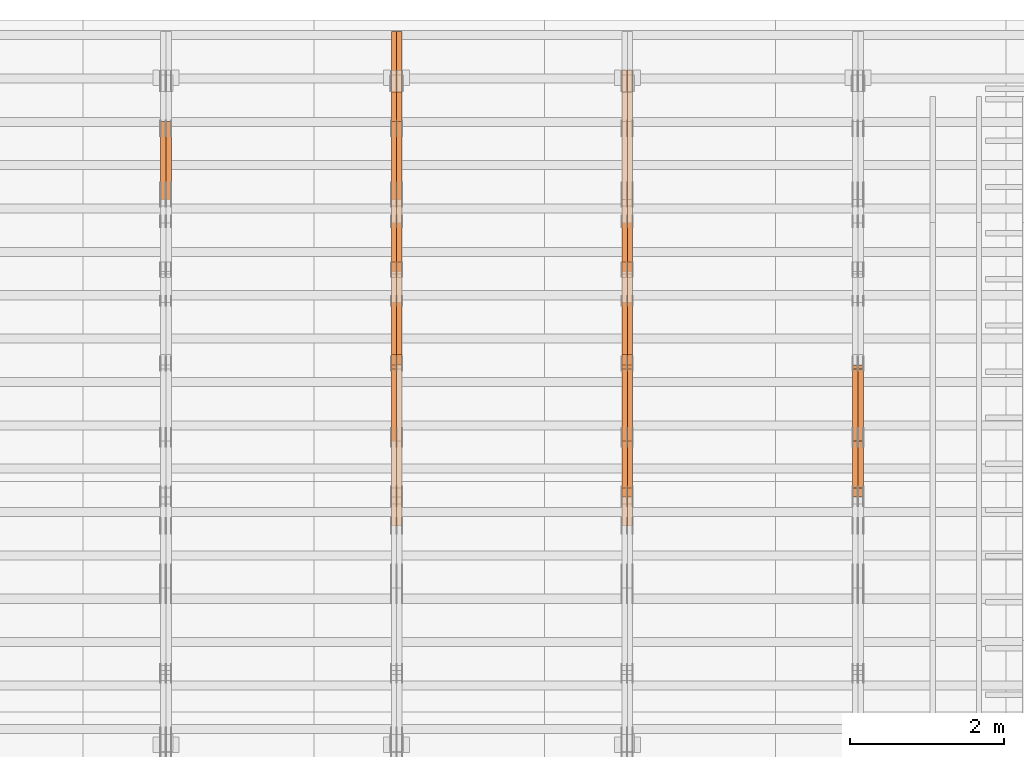
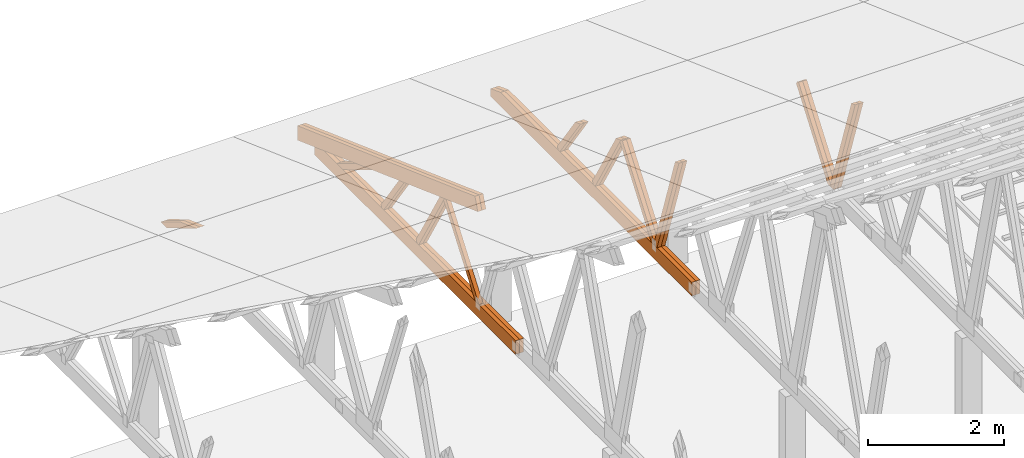
# One storey, part 62 of 189: 27 proxies.
"""IFC2X3 building model written with IfcOpenShell, lengths in millimetres."""

from ifc_helpers import new_model, entity, si_unit, converted_unit, derived_unit, direction, frame, origin, place, context, subcontext, project, spatial, polyline, outline, extrude, source, transform, mapped, material, type_object, type_shapes, element, save


model = new_model("IFC2X3")

# Units and contexts
model_context = context("Model", 3, precision=0.01, world=origin(), true_north=direction((6.12303176911189e-17, 1.0)))
body_context = subcontext(model_context, "Body", "Model", "MODEL_VIEW")
ifc_project = project(units=[si_unit("LENGTHUNIT", "METRE", prefix="MILLI"), si_unit("AREAUNIT", "SQUARE_METRE"), si_unit("VOLUMEUNIT", "CUBIC_METRE"), converted_unit("PLANEANGLEUNIT", "DEGREE", entity("IfcRatioMeasure", 0.0174532925199433), si_unit("PLANEANGLEUNIT", "RADIAN"), dimensions=[0, 0, 0, 0, 0, 0, 0]), si_unit("MASSUNIT", "GRAM", prefix="KILO"), derived_unit("MASSDENSITYUNIT", [(si_unit("MASSUNIT", "GRAM", prefix="KILO"), 1), (si_unit("LENGTHUNIT", "METRE"), -3)]), si_unit("TIMEUNIT", "SECOND"), si_unit("FREQUENCYUNIT", "HERTZ"), si_unit("THERMODYNAMICTEMPERATUREUNIT", "DEGREE_CELSIUS"), derived_unit("THERMALTRANSMITTANCEUNIT", [(si_unit("MASSUNIT", "GRAM", prefix="KILO"), 1), (si_unit("THERMODYNAMICTEMPERATUREUNIT", "KELVIN"), -1), (si_unit("TIMEUNIT", "SECOND"), -3)]), derived_unit("VOLUMETRICFLOWRATEUNIT", [(si_unit("LENGTHUNIT", "METRE"), 3), (si_unit("TIMEUNIT", "SECOND"), -1)]), si_unit("ELECTRICCURRENTUNIT", "AMPERE"), si_unit("ELECTRICVOLTAGEUNIT", "VOLT"), si_unit("POWERUNIT", "WATT"), si_unit("FORCEUNIT", "NEWTON"), si_unit("ILLUMINANCEUNIT", "LUX"), si_unit("LUMINOUSFLUXUNIT", "LUMEN"), si_unit("LUMINOUSINTENSITYUNIT", "CANDELA"), derived_unit("USERDEFINED", [(si_unit("MASSUNIT", "GRAM", prefix="KILO"), -1), (si_unit("LENGTHUNIT", "METRE"), -2), (si_unit("TIMEUNIT", "SECOND"), 3), (si_unit("LUMINOUSFLUXUNIT", "LUMEN"), 1)]), derived_unit("LINEARVELOCITYUNIT", [(si_unit("LENGTHUNIT", "METRE"), 1), (si_unit("TIMEUNIT", "SECOND"), -1)]), si_unit("PRESSUREUNIT", "PASCAL"), derived_unit("USERDEFINED", [(si_unit("LENGTHUNIT", "METRE"), -2), (si_unit("MASSUNIT", "GRAM", prefix="KILO"), 1), (si_unit("TIMEUNIT", "SECOND"), -2)])], contexts=[model_context])

# Site, building, storey
site_placement = place(None, origin())
site = spatial("IfcSite", under=ifc_project, at=site_placement, CompositionType="ELEMENT")
building_placement = place(site_placement, origin())
building = spatial("IfcBuilding", under=site, at=building_placement, CompositionType="ELEMENT")
storey_placement = place(building_placement, origin())
storey = spatial("IfcBuildingStorey", under=building, at=storey_placement, Name="Default", CompositionType="ELEMENT", Elevation=0.0)

# Proxies
ifc_material_1 = material(Name="IfcSurfaceStyle #224290")
building_element_proxy_type_1 = type_object("IfcBuildingElementProxyType", Name="T1-W9 224288", PredefinedType="NOTDEFINED", material=ifc_material_1)
shared_shape_1 = source(origin(), body_context, "Body", "SweptSolid", [
    extrude(outline(polyline([(-1151.44310138162, -47.5000079487596), (776.329826327547, -47.5000079487596), (809.267611644053, -8.1966354137375e-07), (793.242530238244, 47.5000083585914), (-1227.39686682822, 47.5000083585914), (-1151.44310138162, -47.5000079487596)])), frame((809.267685789073, 47.5000083585914, 0.0), z_axis=(0.0, 0.0, 1.0), x_axis=(-1.0, 0.0, 0.0)), (0.0, 0.0, 1.0), 69.9999999999999),
])
type_shapes(building_element_proxy_type_1, [shared_shape_1])
proxy_1_placement = place(building_placement, frame((42300.0, 24600.2198992919, 229.815691184017), z_axis=(-1.0, 0.0, 0.0), x_axis=(0.0, -0.31966811847134, 0.947529574226047)))
element("IfcBuildingElementProxy", 1, at=proxy_1_placement, inside=storey, type_object=building_element_proxy_type_1, material=ifc_material_1, Name="T1-W9", context=body_context, shape_type="MappedRepresentation", body=[
    mapped(shared_shape_1, transform((0.0, 0.0, 0.0), scale=1.0)),
])
ifc_material_2 = material(Name="IfcSurfaceStyle #224224")
building_element_proxy_type_2 = type_object("IfcBuildingElementProxyType", Name="T1-W9 224222", PredefinedType="NOTDEFINED", material=ifc_material_2)
shared_shape_2 = source(origin(), body_context, "Body", "SweptSolid", [
    extrude(outline(polyline([(-1151.44310138162, -47.5000079487596), (776.329826327547, -47.5000079487596), (809.267611644053, -8.1966354137375e-07), (793.242530238244, 47.5000083585914), (-1227.39686682822, 47.5000083585914), (-1151.44310138162, -47.5000079487596)])), frame((809.267685789073, 47.5000083585914, 0.0), z_axis=(0.0, 0.0, 1.0), x_axis=(-1.0, 0.0, 0.0)), (0.0, 0.0, 1.0), 69.9999999999999),
])
type_shapes(building_element_proxy_type_2, [shared_shape_2])
proxy_2_placement = place(building_placement, frame((42230.0, 24600.2198992919, 229.815691184017), z_axis=(-1.0, 0.0, 0.0), x_axis=(0.0, -0.31966811847134, 0.947529574226047)))
element("IfcBuildingElementProxy", 2, at=proxy_2_placement, inside=storey, type_object=building_element_proxy_type_2, material=ifc_material_2, Name="T1-W9", context=body_context, shape_type="MappedRepresentation", body=[
    mapped(shared_shape_2, transform((0.0, 0.0, 0.0), scale=1.0)),
])
ifc_material_3 = material(Name="IfcSurfaceStyle #224026")
building_element_proxy_type_3 = type_object("IfcBuildingElementProxyType", Name="T1-W10 224024", PredefinedType="NOTDEFINED", material=ifc_material_3)
shared_shape_3 = source(origin(), body_context, "Body", "SweptSolid", [
    extrude(outline(polyline([(-993.240970354386, -47.5000757607337), (635.890952815036, -47.5000757607337), (650.068145237537, -1.47580554758164e-05), (629.921374092803, 47.5000831397614), (-922.639501790989, 47.5000831397614), (-993.240970354386, -47.5000757607337)])), frame((650.068173419645, 47.5002811208496, 0.0), z_axis=(0.0, 0.0, 1.0), x_axis=(-1.0, 0.0, 0.0)), (0.0, 0.0, 1.0), 69.9999999999999),
])
type_shapes(building_element_proxy_type_3, [shared_shape_3])
proxy_3_placement = place(building_placement, frame((42300.0, 25701.688098798, 1507.2920009025), z_axis=(-1.0, 0.0, 0.0), x_axis=(0.0, -0.596486092002004, -0.802623412347395)))
element("IfcBuildingElementProxy", 3, at=proxy_3_placement, inside=storey, type_object=building_element_proxy_type_3, material=ifc_material_3, Name="T1-W10", context=body_context, shape_type="MappedRepresentation", body=[
    mapped(shared_shape_3, transform((0.0, 0.0, 0.0), scale=1.0)),
])
ifc_material_4 = material(Name="IfcSurfaceStyle #223960")
building_element_proxy_type_4 = type_object("IfcBuildingElementProxyType", Name="T1-W10 223958", PredefinedType="NOTDEFINED", material=ifc_material_4)
shared_shape_4 = source(origin(), body_context, "Body", "SweptSolid", [
    extrude(outline(polyline([(-993.240970354386, -47.5000757607337), (635.890952815036, -47.5000757607337), (650.068145237537, -1.47580554758164e-05), (629.921374092803, 47.5000831397614), (-922.639501790989, 47.5000831397614), (-993.240970354386, -47.5000757607337)])), frame((650.068173419645, 47.5002811208496, 0.0), z_axis=(0.0, 0.0, 1.0), x_axis=(-1.0, 0.0, 0.0)), (0.0, 0.0, 1.0), 69.9999999999999),
])
type_shapes(building_element_proxy_type_4, [shared_shape_4])
proxy_4_placement = place(building_placement, frame((42230.0, 25701.688098798, 1507.2920009025), z_axis=(-1.0, 0.0, 0.0), x_axis=(0.0, -0.596486092002004, -0.802623412347395)))
element("IfcBuildingElementProxy", 4, at=proxy_4_placement, inside=storey, type_object=building_element_proxy_type_4, material=ifc_material_4, Name="T1-W10", context=body_context, shape_type="MappedRepresentation", body=[
    mapped(shared_shape_4, transform((0.0, 0.0, 0.0), scale=1.0)),
])
ifc_material_5 = material(Name="IfcSurfaceStyle #208500")
building_element_proxy_type_5 = type_object("IfcBuildingElementProxyType", Name="T1-W9 208498", PredefinedType="NOTDEFINED", material=ifc_material_5)
shared_shape_5 = source(origin(), body_context, "Body", "SweptSolid", [
    extrude(outline(polyline([(-1151.44310138162, -47.5000079487596), (776.329826327547, -47.5000079487596), (809.267611644053, -8.1966354137375e-07), (793.242530238244, 47.5000083585914), (-1227.39686682822, 47.5000083585914), (-1151.44310138162, -47.5000079487596)])), frame((809.267685789073, 47.5000083585914, 0.0), z_axis=(0.0, 0.0, 1.0), x_axis=(-1.0, 0.0, 0.0)), (0.0, 0.0, 1.0), 69.9999999999999),
])
type_shapes(building_element_proxy_type_5, [shared_shape_5])
proxy_5_placement = place(building_placement, frame((39300.0, 24600.2198992919, 229.815691184017), z_axis=(-1.0, 0.0, 0.0), x_axis=(0.0, -0.31966811847134, 0.947529574226047)))
element("IfcBuildingElementProxy", 5, at=proxy_5_placement, inside=storey, type_object=building_element_proxy_type_5, material=ifc_material_5, Name="T1-W9", context=body_context, shape_type="MappedRepresentation", body=[
    mapped(shared_shape_5, transform((0.0, 0.0, 0.0), scale=1.0)),
])
ifc_material_6 = material(Name="IfcSurfaceStyle #208434")
building_element_proxy_type_6 = type_object("IfcBuildingElementProxyType", Name="T1-W9 208432", PredefinedType="NOTDEFINED", material=ifc_material_6)
shared_shape_6 = source(origin(), body_context, "Body", "SweptSolid", [
    extrude(outline(polyline([(-1151.44310138162, -47.5000079487596), (776.329826327547, -47.5000079487596), (809.267611644053, -8.1966354137375e-07), (793.242530238244, 47.5000083585914), (-1227.39686682822, 47.5000083585914), (-1151.44310138162, -47.5000079487596)])), frame((809.267685789073, 47.5000083585914, 0.0), z_axis=(0.0, 0.0, 1.0), x_axis=(-1.0, 0.0, 0.0)), (0.0, 0.0, 1.0), 69.9999999999999),
])
type_shapes(building_element_proxy_type_6, [shared_shape_6])
proxy_6_placement = place(building_placement, frame((39230.0, 24600.2198992919, 229.815691184017), z_axis=(-1.0, 0.0, 0.0), x_axis=(0.0, -0.31966811847134, 0.947529574226047)))
element("IfcBuildingElementProxy", 6, at=proxy_6_placement, inside=storey, type_object=building_element_proxy_type_6, material=ifc_material_6, Name="T1-W9", context=body_context, shape_type="MappedRepresentation", body=[
    mapped(shared_shape_6, transform((0.0, 0.0, 0.0), scale=1.0)),
])
ifc_material_7 = material(Name="IfcSurfaceStyle #208236")
building_element_proxy_type_7 = type_object("IfcBuildingElementProxyType", Name="T1-W10 208234", PredefinedType="NOTDEFINED", material=ifc_material_7)
shared_shape_7 = source(origin(), body_context, "Body", "SweptSolid", [
    extrude(outline(polyline([(-993.240970354386, -47.5000757607337), (635.890952815036, -47.5000757607337), (650.068145237537, -1.47580554758164e-05), (629.921374092803, 47.5000831397614), (-922.639501790989, 47.5000831397614), (-993.240970354386, -47.5000757607337)])), frame((650.068173419645, 47.5002811208496, 0.0), z_axis=(0.0, 0.0, 1.0), x_axis=(-1.0, 0.0, 0.0)), (0.0, 0.0, 1.0), 69.9999999999999),
])
type_shapes(building_element_proxy_type_7, [shared_shape_7])
proxy_7_placement = place(building_placement, frame((39300.0, 25701.688098798, 1507.2920009025), z_axis=(-1.0, 0.0, 0.0), x_axis=(0.0, -0.596486092002004, -0.802623412347395)))
element("IfcBuildingElementProxy", 7, at=proxy_7_placement, inside=storey, type_object=building_element_proxy_type_7, material=ifc_material_7, Name="T1-W10", context=body_context, shape_type="MappedRepresentation", body=[
    mapped(shared_shape_7, transform((0.0, 0.0, 0.0), scale=1.0)),
])
ifc_material_8 = material(Name="IfcSurfaceStyle #208170")
building_element_proxy_type_8 = type_object("IfcBuildingElementProxyType", Name="T1-W10 208168", PredefinedType="NOTDEFINED", material=ifc_material_8)
shared_shape_8 = source(origin(), body_context, "Body", "SweptSolid", [
    extrude(outline(polyline([(-993.240970354386, -47.5000757607337), (635.890952815036, -47.5000757607337), (650.068145237537, -1.47580554758164e-05), (629.921374092803, 47.5000831397614), (-922.639501790989, 47.5000831397614), (-993.240970354386, -47.5000757607337)])), frame((650.068173419645, 47.5002811208496, 0.0), z_axis=(0.0, 0.0, 1.0), x_axis=(-1.0, 0.0, 0.0)), (0.0, 0.0, 1.0), 69.9999999999999),
])
type_shapes(building_element_proxy_type_8, [shared_shape_8])
proxy_8_placement = place(building_placement, frame((39230.0, 25701.688098798, 1507.2920009025), z_axis=(-1.0, 0.0, 0.0), x_axis=(0.0, -0.596486092002004, -0.802623412347395)))
element("IfcBuildingElementProxy", 8, at=proxy_8_placement, inside=storey, type_object=building_element_proxy_type_8, material=ifc_material_8, Name="T1-W10", context=body_context, shape_type="MappedRepresentation", body=[
    mapped(shared_shape_8, transform((0.0, 0.0, 0.0), scale=1.0)),
])
ifc_material_9 = material(Name="IfcSurfaceStyle #207972")
building_element_proxy_type_9 = type_object("IfcBuildingElementProxyType", Name="T1-W11 207970", PredefinedType="NOTDEFINED", material=ifc_material_9)
shared_shape_9 = source(origin(), body_context, "Body", "SweptSolid", [
    extrude(outline(polyline([(-809.410890003667, -47.5000077306544), (561.624013869753, -47.5000077306544), (599.944137054867, -7.52294285037536e-05), (572.078784657538, 47.5000453453687), (-924.236045578491, 47.5000453453687), (-809.410890003667, -47.5000077306544)])), frame((599.944137054867, 47.5000453453687, 0.0), z_axis=(0.0, 0.0, 1.0), x_axis=(-1.0, 0.0, 0.0)), (0.0, 0.0, 1.0), 69.9999999999999),
])
type_shapes(building_element_proxy_type_9, [shared_shape_9])
proxy_9_placement = place(building_placement, frame((39300.0, 26434.7921369083, 220.965133687368), z_axis=(-1.0, 0.0, 0.0), x_axis=(0.0, -0.505995901100603, 0.862535882192381)))
element("IfcBuildingElementProxy", 9, at=proxy_9_placement, inside=storey, type_object=building_element_proxy_type_9, material=ifc_material_9, Name="T1-W11", context=body_context, shape_type="MappedRepresentation", body=[
    mapped(shared_shape_9, transform((0.0, 0.0, 0.0), scale=1.0)),
])
ifc_material_10 = material(Name="IfcSurfaceStyle #207906")
building_element_proxy_type_10 = type_object("IfcBuildingElementProxyType", Name="T1-W11 207904", PredefinedType="NOTDEFINED", material=ifc_material_10)
shared_shape_10 = source(origin(), body_context, "Body", "SweptSolid", [
    extrude(outline(polyline([(-809.410890003667, -47.5000077306544), (561.624013869753, -47.5000077306544), (599.944137054867, -7.52294285037536e-05), (572.078784657538, 47.5000453453687), (-924.236045578491, 47.5000453453687), (-809.410890003667, -47.5000077306544)])), frame((599.944137054867, 47.5000453453687, 0.0), z_axis=(0.0, 0.0, 1.0), x_axis=(-1.0, 0.0, 0.0)), (0.0, 0.0, 1.0), 69.9999999999999),
])
type_shapes(building_element_proxy_type_10, [shared_shape_10])
proxy_10_placement = place(building_placement, frame((39230.0, 26434.7921369083, 220.965133687368), z_axis=(-1.0, 0.0, 0.0), x_axis=(0.0, -0.505995901100603, 0.862535882192381)))
element("IfcBuildingElementProxy", 10, at=proxy_10_placement, inside=storey, type_object=building_element_proxy_type_10, material=ifc_material_10, Name="T1-W11", context=body_context, shape_type="MappedRepresentation", body=[
    mapped(shared_shape_10, transform((0.0, 0.0, 0.0), scale=1.0)),
])
ifc_material_11 = material(Name="IfcSurfaceStyle #207444")
building_element_proxy_type_11 = type_object("IfcBuildingElementProxyType", Name="T1-W13 207442", PredefinedType="NOTDEFINED", material=ifc_material_11)
shared_shape_11 = source(origin(), body_context, "Body", "SweptSolid", [
    extrude(outline(polyline([(-527.416466728212, -47.5000272833949), (387.658053197984, -47.5000272833949), (418.029495084182, -7.96824534414764e-06), (384.779443025059, 47.5000312675175), (-663.050524579013, 47.5000312675176), (-527.416466728212, -47.5000272833949)])), frame((418.029495084182, 47.5000671658844, 0.0), z_axis=(0.0, 0.0, 1.0), x_axis=(-1.0, 0.0, 0.0)), (0.0, 0.0, 1.0), 69.9999999999999),
])
type_shapes(building_element_proxy_type_11, [shared_shape_11])
proxy_11_placement = place(building_placement, frame((39300.0, 27471.0085508293, 217.760482033818), z_axis=(-1.0, 0.0, 0.0), x_axis=(0.0, -0.573462629043498, 0.819231721242848)))
element("IfcBuildingElementProxy", 11, at=proxy_11_placement, inside=storey, type_object=building_element_proxy_type_11, material=ifc_material_11, Name="T1-W13", context=body_context, shape_type="MappedRepresentation", body=[
    mapped(shared_shape_11, transform((0.0, 0.0, 0.0), scale=1.0)),
])
ifc_material_12 = material(Name="IfcSurfaceStyle #207378")
building_element_proxy_type_12 = type_object("IfcBuildingElementProxyType", Name="T1-W13 207376", PredefinedType="NOTDEFINED", material=ifc_material_12)
shared_shape_12 = source(origin(), body_context, "Body", "SweptSolid", [
    extrude(outline(polyline([(-527.416466728212, -47.5000272833949), (387.658053197984, -47.5000272833949), (418.029495084182, -7.96824534414764e-06), (384.779443025059, 47.5000312675175), (-663.050524579013, 47.5000312675176), (-527.416466728212, -47.5000272833949)])), frame((418.029495084182, 47.5000671658844, 0.0), z_axis=(0.0, 0.0, 1.0), x_axis=(-1.0, 0.0, 0.0)), (0.0, 0.0, 1.0), 69.9999999999999),
])
type_shapes(building_element_proxy_type_12, [shared_shape_12])
proxy_12_placement = place(building_placement, frame((39230.0, 27471.0085508293, 217.760482033818), z_axis=(-1.0, 0.0, 0.0), x_axis=(0.0, -0.573462629043498, 0.819231721242848)))
element("IfcBuildingElementProxy", 12, at=proxy_12_placement, inside=storey, type_object=building_element_proxy_type_12, material=ifc_material_12, Name="T1-W13", context=body_context, shape_type="MappedRepresentation", body=[
    mapped(shared_shape_12, transform((0.0, 0.0, 0.0), scale=1.0)),
])
ifc_material_13 = material(Name="IfcSurfaceStyle #206820")
building_element_proxy_type_13 = type_object("IfcBuildingElementProxyType", Name="T1-B1 206818", PredefinedType="NOTDEFINED", material=ifc_material_13)
shared_shape_13 = source(origin(), body_context, "Body", "SweptSolid", [
    extrude(outline(polyline([(-2430.09461669922, -125.855288696288), (3499.90538330078, -125.855288696288), (3499.90538330078, 119.144711303711), (-2139.62153320312, 119.144711303711), (-2430.09461669922, 13.4211547851552), (-2430.09461669922, -125.855288696288)])), frame((3499.90538330078, 119.144711303711, 0.0), z_axis=(0.0, 0.0, 1.0), x_axis=(-1.0, 0.0, 0.0)), (0.0, 0.0, 1.0), 69.9999999999996),
])
type_shapes(building_element_proxy_type_13, [shared_shape_13])
proxy_13_placement = place(building_placement, frame((39300.0, 23570.0, 245.0), z_axis=(-1.0, 0.0, 0.0), x_axis=(0.0, 1.0, 0.0)))
element("IfcBuildingElementProxy", 13, at=proxy_13_placement, inside=storey, type_object=building_element_proxy_type_13, material=ifc_material_13, Name="T1-B1", context=body_context, shape_type="MappedRepresentation", body=[
    mapped(shared_shape_13, transform((0.0, 0.0, 0.0), scale=1.0)),
])
ifc_material_14 = material(Name="IfcSurfaceStyle #206754")
building_element_proxy_type_14 = type_object("IfcBuildingElementProxyType", Name="T1-B1 206752", PredefinedType="NOTDEFINED", material=ifc_material_14)
shared_shape_14 = source(origin(), body_context, "Body", "SweptSolid", [
    extrude(outline(polyline([(-2430.09461669922, -125.855288696288), (3499.90538330078, -125.855288696288), (3499.90538330078, 119.144711303711), (-2139.62153320312, 119.144711303711), (-2430.09461669922, 13.4211547851552), (-2430.09461669922, -125.855288696288)])), frame((3499.90538330078, 119.144711303711, 0.0), z_axis=(0.0, 0.0, 1.0), x_axis=(-1.0, 0.0, 0.0)), (0.0, 0.0, 1.0), 69.9999999999996),
])
type_shapes(building_element_proxy_type_14, [shared_shape_14])
proxy_14_placement = place(building_placement, frame((39230.0, 23570.0, 245.0), z_axis=(-1.0, 0.0, 0.0), x_axis=(0.0, 1.0, 0.0)))
element("IfcBuildingElementProxy", 14, at=proxy_14_placement, inside=storey, type_object=building_element_proxy_type_14, material=ifc_material_14, Name="T1-B1", context=body_context, shape_type="MappedRepresentation", body=[
    mapped(shared_shape_14, transform((0.0, 0.0, 0.0), scale=1.0)),
])
ifc_material_15 = material(Name="IfcSurfaceStyle #192380")
building_element_proxy_type_15 = type_object("IfcBuildingElementProxyType", Name="T1-W10 192378", PredefinedType="NOTDEFINED", material=ifc_material_15)
shared_shape_15 = source(origin(), body_context, "Body", "SweptSolid", [
    extrude(outline(polyline([(-993.240970354386, -47.5000757607337), (635.890952815036, -47.5000757607337), (650.068145237537, -1.47580554758164e-05), (629.921374092803, 47.5000831397614), (-922.639501790989, 47.5000831397614), (-993.240970354386, -47.5000757607337)])), frame((650.068173419645, 47.5002811208496, 0.0), z_axis=(0.0, 0.0, 1.0), x_axis=(-1.0, 0.0, 0.0)), (0.0, 0.0, 1.0), 69.9999999999999),
])
type_shapes(building_element_proxy_type_15, [shared_shape_15])
proxy_15_placement = place(building_placement, frame((36230.0, 25701.688098798, 1507.2920009025), z_axis=(-1.0, 0.0, 0.0), x_axis=(0.0, -0.596486092002004, -0.802623412347395)))
element("IfcBuildingElementProxy", 15, at=proxy_15_placement, inside=storey, type_object=building_element_proxy_type_15, material=ifc_material_15, Name="T1-W10", context=body_context, shape_type="MappedRepresentation", body=[
    mapped(shared_shape_15, transform((0.0, 0.0, 0.0), scale=1.0)),
])
ifc_material_16 = material(Name="IfcSurfaceStyle #192182")
building_element_proxy_type_16 = type_object("IfcBuildingElementProxyType", Name="T1-W11 192180", PredefinedType="NOTDEFINED", material=ifc_material_16)
shared_shape_16 = source(origin(), body_context, "Body", "SweptSolid", [
    extrude(outline(polyline([(-809.410890003667, -47.5000077306544), (561.624013869753, -47.5000077306544), (599.944137054867, -7.52294285037536e-05), (572.078784657538, 47.5000453453687), (-924.236045578491, 47.5000453453687), (-809.410890003667, -47.5000077306544)])), frame((599.944137054867, 47.5000453453687, 0.0), z_axis=(0.0, 0.0, 1.0), x_axis=(-1.0, 0.0, 0.0)), (0.0, 0.0, 1.0), 69.9999999999999),
])
type_shapes(building_element_proxy_type_16, [shared_shape_16])
proxy_16_placement = place(building_placement, frame((36300.0, 26434.7921369083, 220.965133687368), z_axis=(-1.0, 0.0, 0.0), x_axis=(0.0, -0.505995901100603, 0.862535882192381)))
element("IfcBuildingElementProxy", 16, at=proxy_16_placement, inside=storey, type_object=building_element_proxy_type_16, material=ifc_material_16, Name="T1-W11", context=body_context, shape_type="MappedRepresentation", body=[
    mapped(shared_shape_16, transform((0.0, 0.0, 0.0), scale=1.0)),
])
ifc_material_17 = material(Name="IfcSurfaceStyle #192116")
building_element_proxy_type_17 = type_object("IfcBuildingElementProxyType", Name="T1-W11 192114", PredefinedType="NOTDEFINED", material=ifc_material_17)
shared_shape_17 = source(origin(), body_context, "Body", "SweptSolid", [
    extrude(outline(polyline([(-809.410890003667, -47.5000077306544), (561.624013869753, -47.5000077306544), (599.944137054867, -7.52294285037536e-05), (572.078784657538, 47.5000453453687), (-924.236045578491, 47.5000453453687), (-809.410890003667, -47.5000077306544)])), frame((599.944137054867, 47.5000453453687, 0.0), z_axis=(0.0, 0.0, 1.0), x_axis=(-1.0, 0.0, 0.0)), (0.0, 0.0, 1.0), 69.9999999999999),
])
type_shapes(building_element_proxy_type_17, [shared_shape_17])
proxy_17_placement = place(building_placement, frame((36230.0, 26434.7921369083, 220.965133687368), z_axis=(-1.0, 0.0, 0.0), x_axis=(0.0, -0.505995901100603, 0.862535882192381)))
element("IfcBuildingElementProxy", 17, at=proxy_17_placement, inside=storey, type_object=building_element_proxy_type_17, material=ifc_material_17, Name="T1-W11", context=body_context, shape_type="MappedRepresentation", body=[
    mapped(shared_shape_17, transform((0.0, 0.0, 0.0), scale=1.0)),
])
ifc_material_18 = material(Name="IfcSurfaceStyle #191654")
building_element_proxy_type_18 = type_object("IfcBuildingElementProxyType", Name="T1-W13 191652", PredefinedType="NOTDEFINED", material=ifc_material_18)
shared_shape_18 = source(origin(), body_context, "Body", "SweptSolid", [
    extrude(outline(polyline([(-527.416466728212, -47.5000272833949), (387.658053197984, -47.5000272833949), (418.029495084182, -7.96824534414764e-06), (384.779443025059, 47.5000312675175), (-663.050524579013, 47.5000312675176), (-527.416466728212, -47.5000272833949)])), frame((418.029495084182, 47.5000671658844, 0.0), z_axis=(0.0, 0.0, 1.0), x_axis=(-1.0, 0.0, 0.0)), (0.0, 0.0, 1.0), 69.9999999999999),
])
type_shapes(building_element_proxy_type_18, [shared_shape_18])
proxy_18_placement = place(building_placement, frame((36300.0, 27471.0085508293, 217.760482033818), z_axis=(-1.0, 0.0, 0.0), x_axis=(0.0, -0.573462629043498, 0.819231721242848)))
element("IfcBuildingElementProxy", 18, at=proxy_18_placement, inside=storey, type_object=building_element_proxy_type_18, material=ifc_material_18, Name="T1-W13", context=body_context, shape_type="MappedRepresentation", body=[
    mapped(shared_shape_18, transform((0.0, 0.0, 0.0), scale=1.0)),
])
ifc_material_19 = material(Name="IfcSurfaceStyle #191588")
building_element_proxy_type_19 = type_object("IfcBuildingElementProxyType", Name="T1-W13 191586", PredefinedType="NOTDEFINED", material=ifc_material_19)
shared_shape_19 = source(origin(), body_context, "Body", "SweptSolid", [
    extrude(outline(polyline([(-527.416466728212, -47.5000272833949), (387.658053197984, -47.5000272833949), (418.029495084182, -7.96824534414764e-06), (384.779443025059, 47.5000312675175), (-663.050524579013, 47.5000312675176), (-527.416466728212, -47.5000272833949)])), frame((418.029495084182, 47.5000671658844, 0.0), z_axis=(0.0, 0.0, 1.0), x_axis=(-1.0, 0.0, 0.0)), (0.0, 0.0, 1.0), 69.9999999999999),
])
type_shapes(building_element_proxy_type_19, [shared_shape_19])
proxy_19_placement = place(building_placement, frame((36230.0, 27471.0085508293, 217.760482033818), z_axis=(-1.0, 0.0, 0.0), x_axis=(0.0, -0.573462629043498, 0.819231721242848)))
element("IfcBuildingElementProxy", 19, at=proxy_19_placement, inside=storey, type_object=building_element_proxy_type_19, material=ifc_material_19, Name="T1-W13", context=body_context, shape_type="MappedRepresentation", body=[
    mapped(shared_shape_19, transform((0.0, 0.0, 0.0), scale=1.0)),
])
ifc_material_20 = material(Name="IfcSurfaceStyle #191144")
building_element_proxy_type_20 = type_object("IfcBuildingElementProxyType", Name="T1-W12 191142", PredefinedType="NOTDEFINED", material=ifc_material_20)
shared_shape_20 = source(origin(), body_context, "Body", "SweptSolid", [
    extrude(outline(polyline([(-176.861423449428, -47.5000064161489), (503.856777435794, -47.5000064161489), (344.893496040196, 47.5000064161489), (-671.888850026563, 47.5000064161488), (-176.861423449428, -47.5000064161489)])), frame((503.856799890979, 47.5000428456028, 0.0), z_axis=(0.0, 0.0, 1.0), x_axis=(-1.0, 0.0, 0.0)), (0.0, 0.0, 1.0), 69.9999999999999),
])
type_shapes(building_element_proxy_type_20, [shared_shape_20])
proxy_20_placement = place(building_placement, frame((36300.0, 28785.6842742264, 163.452728724015), z_axis=(-1.0, 0.0, 0.0), x_axis=(0.0, -0.858392121304013, 0.51299411895576)))
element("IfcBuildingElementProxy", 20, at=proxy_20_placement, inside=storey, type_object=building_element_proxy_type_20, material=ifc_material_20, Name="T1-W12", context=body_context, shape_type="MappedRepresentation", body=[
    mapped(shared_shape_20, transform((0.0, 0.0, 0.0), scale=1.0)),
])
ifc_material_21 = material(Name="IfcSurfaceStyle #191087")
building_element_proxy_type_21 = type_object("IfcBuildingElementProxyType", Name="T1-W12 191085", PredefinedType="NOTDEFINED", material=ifc_material_21)
shared_shape_21 = source(origin(), body_context, "Body", "SweptSolid", [
    extrude(outline(polyline([(-176.861423449428, -47.5000064161489), (503.856777435794, -47.5000064161489), (344.893496040196, 47.5000064161489), (-671.888850026563, 47.5000064161488), (-176.861423449428, -47.5000064161489)])), frame((503.856799890979, 47.5000428456028, 0.0), z_axis=(0.0, 0.0, 1.0), x_axis=(-1.0, 0.0, 0.0)), (0.0, 0.0, 1.0), 69.9999999999999),
])
type_shapes(building_element_proxy_type_21, [shared_shape_21])
proxy_21_placement = place(building_placement, frame((36230.0, 28785.6842742264, 163.452728724015), z_axis=(-1.0, 0.0, 0.0), x_axis=(0.0, -0.858392121304013, 0.51299411895576)))
element("IfcBuildingElementProxy", 21, at=proxy_21_placement, inside=storey, type_object=building_element_proxy_type_21, material=ifc_material_21, Name="T1-W12", context=body_context, shape_type="MappedRepresentation", body=[
    mapped(shared_shape_21, transform((0.0, 0.0, 0.0), scale=1.0)),
])
ifc_material_22 = material(Name="IfcSurfaceStyle #191030")
building_element_proxy_type_22 = type_object("IfcBuildingElementProxyType", Name="T1-B1 191028", PredefinedType="NOTDEFINED", material=ifc_material_22)
shared_shape_22 = source(origin(), body_context, "Body", "SweptSolid", [
    extrude(outline(polyline([(-2430.09461669922, -125.855288696288), (3499.90538330078, -125.855288696288), (3499.90538330078, 119.144711303711), (-2139.62153320312, 119.144711303711), (-2430.09461669922, 13.4211547851552), (-2430.09461669922, -125.855288696288)])), frame((3499.90538330078, 119.144711303711, 0.0), z_axis=(0.0, 0.0, 1.0), x_axis=(-1.0, 0.0, 0.0)), (0.0, 0.0, 1.0), 69.9999999999996),
])
type_shapes(building_element_proxy_type_22, [shared_shape_22])
proxy_22_placement = place(building_placement, frame((36300.0, 23570.0, 245.0), z_axis=(-1.0, 0.0, 0.0), x_axis=(0.0, 1.0, 0.0)))
element("IfcBuildingElementProxy", 22, at=proxy_22_placement, inside=storey, type_object=building_element_proxy_type_22, material=ifc_material_22, Name="T1-B1", context=body_context, shape_type="MappedRepresentation", body=[
    mapped(shared_shape_22, transform((0.0, 0.0, 0.0), scale=1.0)),
])
ifc_material_23 = material(Name="IfcSurfaceStyle #190964")
building_element_proxy_type_23 = type_object("IfcBuildingElementProxyType", Name="T1-B1 190962", PredefinedType="NOTDEFINED", material=ifc_material_23)
shared_shape_23 = source(origin(), body_context, "Body", "SweptSolid", [
    extrude(outline(polyline([(-2430.09461669922, -125.855288696288), (3499.90538330078, -125.855288696288), (3499.90538330078, 119.144711303711), (-2139.62153320312, 119.144711303711), (-2430.09461669922, 13.4211547851552), (-2430.09461669922, -125.855288696288)])), frame((3499.90538330078, 119.144711303711, 0.0), z_axis=(0.0, 0.0, 1.0), x_axis=(-1.0, 0.0, 0.0)), (0.0, 0.0, 1.0), 69.9999999999996),
])
type_shapes(building_element_proxy_type_23, [shared_shape_23])
proxy_23_placement = place(building_placement, frame((36230.0, 23570.0, 245.0), z_axis=(-1.0, 0.0, 0.0), x_axis=(0.0, 1.0, 0.0)))
element("IfcBuildingElementProxy", 23, at=proxy_23_placement, inside=storey, type_object=building_element_proxy_type_23, material=ifc_material_23, Name="T1-B1", context=body_context, shape_type="MappedRepresentation", body=[
    mapped(shared_shape_23, transform((0.0, 0.0, 0.0), scale=1.0)),
])
ifc_material_24 = material(Name="IfcSurfaceStyle #189740")
building_element_proxy_type_24 = type_object("IfcBuildingElementProxyType", Name="T1-T2 189738", PredefinedType="NOTDEFINED", material=ifc_material_24)
shared_shape_24 = source(origin(), body_context, "Body", "SweptSolid", [
    extrude(outline(polyline([(-2807.70681121203, -122.500041939424), (2763.12044548192, -122.500041939424), (2852.29315104137, 122.500041939424), (-2807.70678531126, 122.500041939424), (-2807.70681121203, -122.500041939424)])), frame((2852.29315104137, 122.500041939424, 0.0), z_axis=(0.0, 0.0, 1.0), x_axis=(-1.0, 0.0, 0.0)), (0.0, 0.0, 1.0), 69.9999999999997),
])
type_shapes(building_element_proxy_type_24, [shared_shape_24])
proxy_24_placement = place(building_placement, frame((36300.0, 30000.0, -42.7086715698242), z_axis=(-1.0, 0.0, 0.0), x_axis=(0.0, -0.939692620785908, 0.342020143325669)))
element("IfcBuildingElementProxy", 24, at=proxy_24_placement, inside=storey, type_object=building_element_proxy_type_24, material=ifc_material_24, Name="T1-T2", context=body_context, shape_type="MappedRepresentation", body=[
    mapped(shared_shape_24, transform((0.0, 0.0, 0.0), scale=1.0)),
])
ifc_material_25 = material(Name="IfcSurfaceStyle #189683")
building_element_proxy_type_25 = type_object("IfcBuildingElementProxyType", Name="T1-T2 189681", PredefinedType="NOTDEFINED", material=ifc_material_25)
shared_shape_25 = source(origin(), body_context, "Body", "SweptSolid", [
    extrude(outline(polyline([(-2807.70681121203, -122.500041939424), (2763.12044548192, -122.500041939424), (2852.29315104137, 122.500041939424), (-2807.70678531126, 122.500041939424), (-2807.70681121203, -122.500041939424)])), frame((2852.29315104137, 122.500041939424, 0.0), z_axis=(0.0, 0.0, 1.0), x_axis=(-1.0, 0.0, 0.0)), (0.0, 0.0, 1.0), 69.9999999999997),
])
type_shapes(building_element_proxy_type_25, [shared_shape_25])
proxy_25_placement = place(building_placement, frame((36230.0, 30000.0, -42.7086715698242), z_axis=(-1.0, 0.0, 0.0), x_axis=(0.0, -0.939692620785908, 0.342020143325669)))
element("IfcBuildingElementProxy", 25, at=proxy_25_placement, inside=storey, type_object=building_element_proxy_type_25, material=ifc_material_25, Name="T1-T2", context=body_context, shape_type="MappedRepresentation", body=[
    mapped(shared_shape_25, transform((0.0, 0.0, 0.0), scale=1.0)),
])
ifc_material_26 = material(Name="IfcSurfaceStyle #175354")
building_element_proxy_type_26 = type_object("IfcBuildingElementProxyType", Name="T1-W12 175352", PredefinedType="NOTDEFINED", material=ifc_material_26)
shared_shape_26 = source(origin(), body_context, "Body", "SweptSolid", [
    extrude(outline(polyline([(-176.861423449428, -47.5000064161489), (503.856777435794, -47.5000064161489), (344.893496040196, 47.5000064161489), (-671.888850026563, 47.5000064161488), (-176.861423449428, -47.5000064161489)])), frame((503.856799890979, 47.5000428456028, 0.0), z_axis=(0.0, 0.0, 1.0), x_axis=(-1.0, 0.0, 0.0)), (0.0, 0.0, 1.0), 69.9999999999999),
])
type_shapes(building_element_proxy_type_26, [shared_shape_26])
proxy_26_placement = place(building_placement, frame((33300.0, 28785.6842742264, 163.452728724015), z_axis=(-1.0, 0.0, 0.0), x_axis=(0.0, -0.858392121304013, 0.51299411895576)))
element("IfcBuildingElementProxy", 26, at=proxy_26_placement, inside=storey, type_object=building_element_proxy_type_26, material=ifc_material_26, Name="T1-W12", context=body_context, shape_type="MappedRepresentation", body=[
    mapped(shared_shape_26, transform((0.0, 0.0, 0.0), scale=1.0)),
])
ifc_material_27 = material(Name="IfcSurfaceStyle #175297")
building_element_proxy_type_27 = type_object("IfcBuildingElementProxyType", Name="T1-W12 175295", PredefinedType="NOTDEFINED", material=ifc_material_27)
shared_shape_27 = source(origin(), body_context, "Body", "SweptSolid", [
    extrude(outline(polyline([(-176.861423449428, -47.5000064161489), (503.856777435794, -47.5000064161489), (344.893496040196, 47.5000064161489), (-671.888850026563, 47.5000064161488), (-176.861423449428, -47.5000064161489)])), frame((503.856799890979, 47.5000428456028, 0.0), z_axis=(0.0, 0.0, 1.0), x_axis=(-1.0, 0.0, 0.0)), (0.0, 0.0, 1.0), 69.9999999999999),
])
type_shapes(building_element_proxy_type_27, [shared_shape_27])
proxy_27_placement = place(building_placement, frame((33230.0, 28785.6842742264, 163.452728724015), z_axis=(-1.0, 0.0, 0.0), x_axis=(0.0, -0.858392121304013, 0.51299411895576)))
element("IfcBuildingElementProxy", 27, at=proxy_27_placement, inside=storey, type_object=building_element_proxy_type_27, material=ifc_material_27, Name="T1-W12", context=body_context, shape_type="MappedRepresentation", body=[
    mapped(shared_shape_27, transform((0.0, 0.0, 0.0), scale=1.0)),
])

save(model, "model.ifc")
